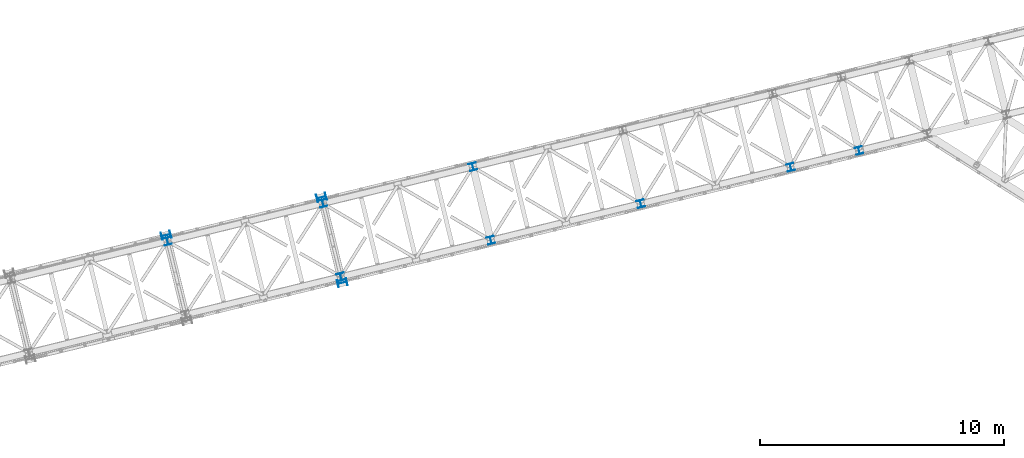
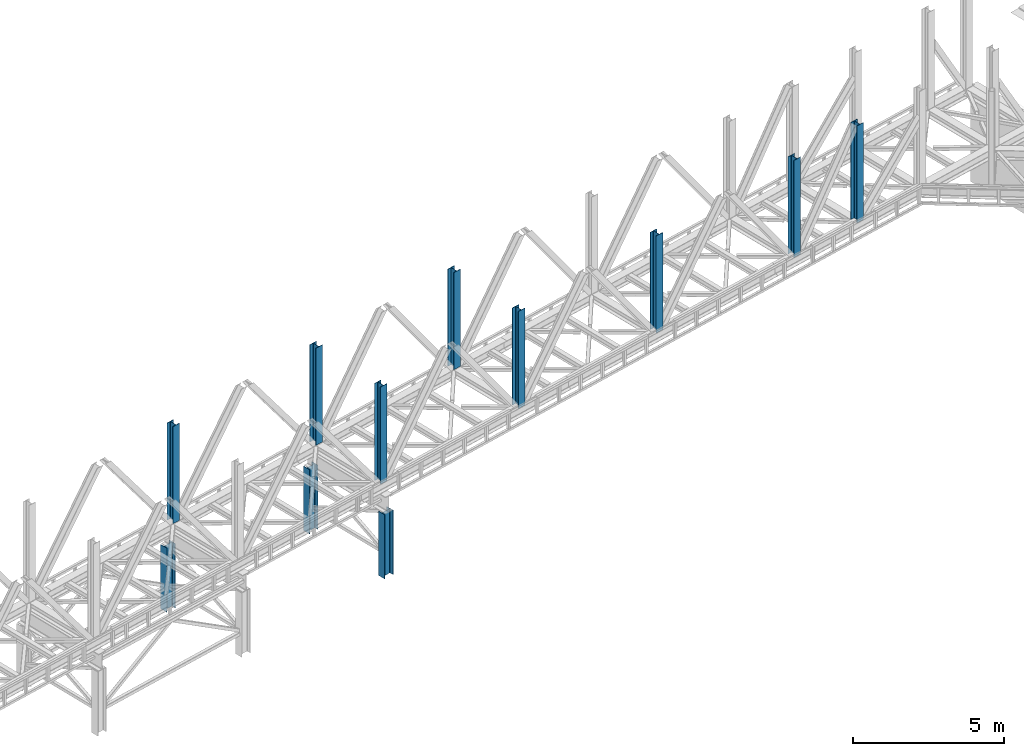
# One storey, part 2 of 92: 11 columns.
"""IFC4 building model written with IfcOpenShell, lengths in millimetres."""

from ifc_helpers import new_model, entity, si_unit, converted_unit, derived_unit, direction, frame, origin, place, context, subcontext, project, spatial, indexed_curve, outline, extrude, type_object, element, save


model = new_model("IFC4")

# Units and contexts
model_context = context("Model", 3, precision=0.01, world=origin(), true_north=direction((6.12303176911189e-17, 1.0)))
plan_context = context("Plan", 3, precision=0.01, world=origin(), true_north=direction((6.12303176911189e-17, 1.0)))
body_context = subcontext(model_context, "Body", "Model", "MODEL_VIEW")
ifc_project = project(units=[si_unit("LENGTHUNIT", "METRE", prefix="MILLI"), si_unit("AREAUNIT", "SQUARE_METRE"), si_unit("VOLUMEUNIT", "CUBIC_METRE"), converted_unit("PLANEANGLEUNIT", "DEGREE", entity("IfcRatioMeasure", 0.0174532925199433), si_unit("PLANEANGLEUNIT", "RADIAN"), dimensions=[0, 0, 0, 0, 0, 0, 0]), si_unit("MASSUNIT", "GRAM", prefix="KILO"), derived_unit("MASSDENSITYUNIT", [(si_unit("MASSUNIT", "GRAM", prefix="KILO"), 1), (si_unit("LENGTHUNIT", "METRE"), -3)]), derived_unit("MOMENTOFINERTIAUNIT", [(si_unit("LENGTHUNIT", "METRE"), 4)]), si_unit("TIMEUNIT", "SECOND"), si_unit("FREQUENCYUNIT", "HERTZ"), si_unit("THERMODYNAMICTEMPERATUREUNIT", "DEGREE_CELSIUS"), derived_unit("THERMALTRANSMITTANCEUNIT", [(si_unit("MASSUNIT", "GRAM", prefix="KILO"), 1), (si_unit("THERMODYNAMICTEMPERATUREUNIT", "KELVIN"), -1), (si_unit("TIMEUNIT", "SECOND"), -3)]), derived_unit("VOLUMETRICFLOWRATEUNIT", [(si_unit("LENGTHUNIT", "METRE"), 3), (si_unit("TIMEUNIT", "SECOND"), -1)]), derived_unit("MASSFLOWRATEUNIT", [(si_unit("MASSUNIT", "GRAM", prefix="KILO"), 1), (si_unit("TIMEUNIT", "SECOND"), -1)]), derived_unit("ROTATIONALFREQUENCYUNIT", [(si_unit("TIMEUNIT", "SECOND"), -1)]), si_unit("ELECTRICCURRENTUNIT", "AMPERE"), si_unit("ELECTRICVOLTAGEUNIT", "VOLT"), si_unit("POWERUNIT", "WATT"), si_unit("FORCEUNIT", "NEWTON", prefix="KILO"), si_unit("ILLUMINANCEUNIT", "LUX"), si_unit("LUMINOUSFLUXUNIT", "LUMEN"), si_unit("LUMINOUSINTENSITYUNIT", "CANDELA"), derived_unit("USERDEFINED", [(si_unit("MASSUNIT", "GRAM", prefix="KILO"), -1), (si_unit("LENGTHUNIT", "METRE"), -2), (si_unit("TIMEUNIT", "SECOND"), 3), (si_unit("LUMINOUSFLUXUNIT", "LUMEN"), 1)]), derived_unit("LINEARVELOCITYUNIT", [(si_unit("LENGTHUNIT", "METRE"), 1), (si_unit("TIMEUNIT", "SECOND"), -1)]), si_unit("PRESSUREUNIT", "PASCAL"), derived_unit("USERDEFINED", [(si_unit("LENGTHUNIT", "METRE"), -2), (si_unit("MASSUNIT", "GRAM", prefix="KILO"), 1), (si_unit("TIMEUNIT", "SECOND"), -2)]), derived_unit("LINEARFORCEUNIT", [(si_unit("MASSUNIT", "GRAM", prefix="KILO"), 1), (si_unit("LENGTHUNIT", "METRE"), 1), (si_unit("TIMEUNIT", "SECOND"), -2), (si_unit("LENGTHUNIT", "METRE"), -1)]), derived_unit("PLANARFORCEUNIT", [(si_unit("MASSUNIT", "GRAM", prefix="KILO"), 1), (si_unit("LENGTHUNIT", "METRE"), 1), (si_unit("TIMEUNIT", "SECOND"), -2), (si_unit("LENGTHUNIT", "METRE"), -2)])], contexts=[model_context, plan_context])

# Site, building, storey
site_placement = place(None, origin())
site = spatial("IfcSite", under=ifc_project, at=site_placement, CompositionType="ELEMENT")
building_placement = place(site_placement, origin())
building = spatial("IfcBuilding", under=site, at=building_placement, CompositionType="ELEMENT")
storey_placement = place(building_placement, frame((0.0, 0.0, 15900.0)))
storey = spatial("IfcBuildingStorey", under=building, at=storey_placement, Name="05", CompositionType="ELEMENT", Elevation=15900.0)

# Columns
column_type_1 = type_object("IfcColumnType", PredefinedType="COLUMN")
placement = place(storey_placement, origin())
element("IfcColumn", 1, at=placement, inside=storey, type_object=column_type_1, ObjectType="Steel Column", PredefinedType="COLUMN", context=body_context, shape_type="SweptSolid", body=[
    extrude(outline(indexed_curve([(-195.999999999997, -150.000000000012), (-179.999999999993, -150.000000000012), (-180.000000000005, -27.7500000000105), (-178.325349715255, -19.3309644879809), (-173.556349186107, -12.1936508139067), (-166.419035512036, -7.42465028476287), (-158.000000000007, -5.75000000001078), (157.999999999993, -5.74999999998623), (166.419035512024, -7.42465028473864), (173.5563491861, -12.19365081388), (178.325349715248, -19.3309644879522), (179.999999999997, -27.7499999999852), (180.000000000005, -149.999999999983), (196.000000000003, -149.999999999984), (195.99999999998, 150.000000000016), (179.999999999985, 150.000000000014), (179.999999999993, 27.7500000000157), (178.325349715242, 19.330964487984), (173.556349186095, 12.1936508139119), (166.419035512023, 7.42465028476595), (157.99999999999, 5.75000000001489), (-158.000000000005, 5.74999999998931), (-166.419035512038, 7.42465028473751), (-173.556349186113, 12.193650813881), (-178.32534971526, 19.3309644879574), (-180.000000000009, 27.7499999999883), (-180.000000000012, 149.999999999987), (-196.000000000016, 149.999999999985), (-195.999999999997, -150.000000000012)], self_intersect=False)), frame((-36585.9, 12131.47, -2.0), z_axis=(0.0, 0.0, 1.0), x_axis=(-0.971552058141491, -0.236826092990264, 0.0)), (0.0, 0.0, 1.0), 2597.00000000003),
])
column_type_2 = type_object("IfcColumnType", PredefinedType="COLUMN")
element("IfcColumn", 2, at=placement, inside=storey, type_object=column_type_2, ObjectType="Steel Column", PredefinedType="COLUMN", context=body_context, shape_type="SweptSolid", body=[
    extrude(outline(indexed_curve([(-195.999999999997, -150.000000000014), (-179.999999999994, -150.000000000014), (-180.000000000001, -27.7500000000136), (-178.325349715246, -19.330964487983), (-173.556349186108, -12.1936508139088), (-166.419035512036, -7.42465028476496), (-158.000000000002, -5.7500000000118), (157.999999999997, -5.74999999998937), (166.419035512032, -7.4246502847407), (173.556349186103, -12.1936508138831), (178.325349715247, -19.3309644879543), (179.999999999996, -27.7499999999873), (180.000000000004, -149.999999999985), (196.000000000012, -149.999999999986), (195.999999999988, 150.000000000014), (179.999999999981, 150.000000000015), (179.999999999992, 27.7500000000136), (178.325349715242, 19.3309644879819), (173.556349186103, 12.1936508139098), (166.419035512032, 7.42465028476389), (157.999999999994, 5.75000000001175), (-158.000000000006, 5.74999999998511), (-166.419035512042, 7.42465028473853), (-173.556349186109, 12.1936508138799), (-178.325349715253, 19.3309644879512), (-180.000000000014, 27.7499999999872), (-180.000000000013, 149.999999999985), (-196.000000000021, 149.999999999986), (-195.999999999997, -150.000000000014)], self_intersect=False)), frame((-29369.65, 10185.09, -1.99), z_axis=(0.0, 0.0, 1.0), x_axis=(-0.971552058141491, -0.236826092990264, 0.0)), (0.0, 0.0, 1.0), 2596.99999999999),
])
column_type_3 = type_object("IfcColumnType", PredefinedType="COLUMN")
element("IfcColumn", 3, at=placement, inside=storey, type_object=column_type_3, ObjectType="Steel Column", PredefinedType="COLUMN", context=body_context, shape_type="SweptSolid", body=[
    extrude(outline(indexed_curve([(-195.99999999998, -150.000000000018), (-179.999999999977, -150.000000000018), (-179.999999999988, -27.7500000000167), (-178.325349715238, -19.330964487985), (-173.556349186095, -12.1936508139119), (-166.419035512024, -7.42465028476805), (-157.999999999986, -5.75000000001591), (158.000000000014, -5.74999999999136), (166.419035512041, -7.42465028474274), (173.556349186116, -12.1936508138862), (178.32534971526, -19.3309644879574), (180.000000000009, -27.7499999999904), (180.000000000017, -149.999999999989), (196.00000000002, -149.999999999989), (195.999999999997, 150.000000000012), (179.999999999997, 150.000000000009), (180.000000000005, 27.7500000000105), (178.325349715254, 19.3309644879788), (173.556349186111, 12.1936508139057), (166.41903551204, 7.42465028476185), (158.00000000001, 5.75000000000765), (-157.99999999998, 5.74999999998316), (-166.41903551202, 7.42465028473551), (-173.556349186095, 12.1936508138811), (-178.325349715243, 19.3309644879533), (-179.999999999988, 27.7499999999831), (-179.999999999997, 149.999999999979), (-196.0, 149.999999999981), (-195.99999999998, -150.000000000018)], self_intersect=False)), frame((-30222.23, 13682.68, -2.0), z_axis=(0.0, 0.0, 1.0), x_axis=(-0.971552058141491, -0.236826092990264, 0.0)), (0.0, 0.0, 1.0), 2597.00000000003),
])
column_type_4 = type_object("IfcColumnType", PredefinedType="COLUMN")
element("IfcColumn", 4, at=placement, inside=storey, type_object=column_type_4, ObjectType="Steel Column", PredefinedType="COLUMN", context=body_context, shape_type="SweptSolid", body=[
    extrude(outline(indexed_curve([(-150.000000000029, -149.999999999968), (-134.500000000028, -149.999999999968), (-134.500000000003, -22.9999999999673), (-133.129831585205, -16.1116982173917), (-129.227922061358, -10.2720779386086), (-123.388301782571, -6.37016841476942), (-116.499999999999, -4.99999999996918), (116.500000000001, -5.00000000001784), (123.388301782572, -6.37016841481622), (129.227922061356, -10.2720779386569), (133.129831585201, -16.1116982174475), (134.499999999996, -23.0000000000225), (134.499999999971, -150.000000000024), (149.999999999971, -150.000000000028), (150.000000000031, 149.999999999977), (134.50000000003, 149.999999999977), (134.500000000006, 22.9999999999799), (133.129831585206, 16.1116982174049), (129.227922061361, 10.2720779386212), (123.388301782575, 6.37016841477732), (116.500000000001, 4.9999999999776), (-116.5, 5.00000000002205), (-123.388301782573, 6.37016841482094), (-129.227922061356, 10.2720779386658), (-133.129831585201, 16.1116982174564), (-134.499999999999, 23.000000000032), (-134.499999999972, 150.000000000028), (-149.999999999969, 150.000000000036), (-150.000000000029, -149.999999999968)], self_intersect=False)), frame((-29428.87, 10427.98, 3685.0), z_axis=(0.0, 0.0, 1.0), x_axis=(-0.236826092990533, 0.971552058141425, 0.0)), (0.0, 0.0, 1.0), 3931.00000000001),
])
column_type_5 = type_object("IfcColumnType", PredefinedType="COLUMN")
element("IfcColumn", 5, at=placement, inside=storey, type_object=column_type_5, ObjectType="Steel Column", PredefinedType="COLUMN", context=body_context, shape_type="SweptSolid", body=[
    extrude(outline(indexed_curve([(-149.999999999989, -150.000000000009), (-134.499999999988, -150.000000000009), (-134.499999999996, -23.0000000000127), (-133.129831585202, -16.111698217441), (-129.227922061358, -10.2720779386521), (-123.388301782571, -6.37016841480712), (-116.499999999999, -5.00000000000502), (116.500000000001, -4.99999999999042), (123.388301782575, -6.37016841478744), (129.227922061359, -10.2720779386307), (133.129831585205, -16.1116982174245), (134.500000000003, -22.9999999999949), (134.500000000013, -149.999999999992), (150.000000000011, -149.999999999991), (149.999999999992, 150.000000000013), (134.499999999991, 150.000000000008), (134.499999999998, 23.0000000000033), (133.129831585202, 16.1116982174321), (129.227922061359, 10.2720779386474), (123.388301782573, 6.37016841480661), (116.500000000002, 5.00000000000871), (-116.499999999999, 4.99999999998991), (-123.388301782572, 6.37016841478693), (-129.227922061357, 10.2720779386302), (-133.129831585205, 16.1116982174156), (-134.500000000002, 22.9999999999902), (-134.50000000001, 149.999999999991), (-150.000000000009, 149.999999999991), (-149.999999999989, -150.000000000009)], self_intersect=False)), frame((-23288.66, 11924.72, 3685.0), z_axis=(0.0, 0.0, 1.0), x_axis=(-0.236826092990269, 0.97155205814149, 0.0)), (0.0, 0.0, 1.0), 3931.00000000001),
])
column_type_6 = type_object("IfcColumnType", PredefinedType="COLUMN")
element("IfcColumn", 6, at=placement, inside=storey, type_object=column_type_6, ObjectType="Steel Column", PredefinedType="COLUMN", context=body_context, shape_type="SweptSolid", body=[
    extrude(outline(indexed_curve([(-149.99999999999, -150.000000000013), (-134.499999999989, -150.000000000013), (-134.499999999999, -23.0000000000143), (-133.129831585202, -16.1116982174342), (-129.227922061359, -10.2720779386563), (-123.388301782571, -6.3701684147982), (-116.5, -5.0000000000003), (116.500000000001, -4.9999999999836), (123.388301782571, -6.3701684147822), (129.227922061357, -10.2720779386391), (133.129831585205, -16.1116982174156), (134.5, -22.9999999999965), (134.50000000001, -149.999999999993), (150.000000000011, -149.999999999991), (149.999999999989, 150.000000000009), (134.499999999988, 150.000000000009), (134.499999999998, 23.0000000000101), (133.129831585201, 16.11169821743), (129.227922061358, 10.2720779386432), (123.388301782572, 6.37016841481134), (116.499999999999, 5.00000000001395), (-116.500000000005, 4.99999999999355), (-123.388301782578, 6.37016841479056), (-129.22792206136, 10.2720779386286), (-133.129831585208, 16.1116982174119), (-134.500000000004, 22.9999999999997), (-134.500000000012, 149.999999999994), (-150.000000000012, 149.999999999987), (-149.99999999999, -150.000000000013)], self_intersect=False)), frame((-17148.45, 13421.46, 3685.0), z_axis=(0.0, 0.0, 1.0), x_axis=(-0.236826092990269, 0.97155205814149, 0.0)), (0.0, 0.0, 1.0), 3931.00000000001),
])
column_type_7 = type_object("IfcColumnType", PredefinedType="COLUMN")
element("IfcColumn", 7, at=placement, inside=storey, type_object=column_type_7, ObjectType="Steel Column", PredefinedType="COLUMN", context=body_context, shape_type="SweptSolid", body=[
    extrude(outline(indexed_curve([(-149.999999999989, -150.000000000011), (-134.499999999989, -150.000000000011), (-134.499999999998, -23.0000000000033), (-133.129831585202, -16.111698217441), (-129.227922061358, -10.2720779386542), (-123.388301782572, -6.37016841480451), (-116.5, -5.00000000000713), (116.500000000001, -4.99999999999042), (123.388301782572, -6.37016841478903), (129.227922061358, -10.272077938637), (133.129831585205, -16.1116982174224), (134.500000000003, -22.999999999986), (134.50000000001, -149.999999999991), (150.000000000011, -149.999999999989), (149.999999999989, 150.000000000011), (134.499999999989, 150.000000000011), (134.499999999998, 23.0000000000122), (133.129831585202, 16.111698217441), (129.227922061356, 10.2720779386547), (123.38830178257, 6.37016841480503), (116.5, 5.00000000000713), (-116.500000000003, 4.99999999998411), (-123.388301782573, 6.37016841478482), (-129.227922061361, 10.2720779386312), (-133.129831585207, 16.1116982174229), (-134.500000000004, 22.9999999999907), (-134.500000000014, 149.999999999988), (-150.000000000011, 149.999999999989), (-149.999999999989, -150.000000000011)], self_intersect=False)), frame((-11008.24, 14918.2, 3685.0), z_axis=(0.0, 0.0, 1.0), x_axis=(-0.236826092990269, 0.97155205814149, 0.0)), (0.0, 0.0, 1.0), 3931.00000000001),
])
column_type_8 = type_object("IfcColumnType", PredefinedType="COLUMN")
element("IfcColumn", 8, at=placement, inside=storey, type_object=column_type_8, ObjectType="Steel Column", PredefinedType="COLUMN", context=body_context, shape_type="SweptSolid", body=[
    extrude(outline(indexed_curve([(-150.000000000006, -149.999999999994), (-134.500000000008, -149.999999999994), (-134.500000000003, -22.9999999999892), (-133.129831585205, -16.111698217426), (-129.227922061361, -10.2720779386396), (-123.388301782575, -6.37016841479049), (-116.500000000002, -4.9999999999938), (116.499999999999, -5.00000000000062), (123.38830178257, -6.37016841479887), (129.227922061355, -10.2720779386485), (133.129831585202, -16.1116982174343), (134.499999999999, -22.999999999997), (134.499999999993, -150.000000000003), (149.999999999994, -150.000000000004), (150.000000000002, 149.999999999998), (134.500000000002, 149.999999999998), (134.499999999999, 22.9999999999923), (133.129831585202, 16.1116982174291), (129.227922061355, 10.2720779386353), (123.388301782569, 6.37016841480306), (116.499999999998, 5.00000000000586), (-116.500000000006, 4.99999999999901), (-123.388301782581, 6.37016841479828), (-129.227922061362, 10.2720779386369), (-133.12983158521, 16.1116982174374), (-134.500000000003, 22.999999999998), (-134.5, 150.000000000003), (-149.999999999998, 150.000000000007), (-150.000000000006, -149.999999999994)], self_intersect=False)), frame((-8210.17, 15600.26, 3685.0), z_axis=(0.0, 0.0, 1.0), x_axis=(-0.236826092990367, 0.971552058141466, 0.0)), (0.0, 0.0, 1.0), 3931.00000000001),
])
column_type_9 = type_object("IfcColumnType", PredefinedType="COLUMN")
element("IfcColumn", 9, at=placement, inside=storey, type_object=column_type_9, ObjectType="Steel Column", PredefinedType="COLUMN", context=body_context, shape_type="SweptSolid", body=[
    extrude(outline(indexed_curve([(-149.999999999993, -149.999999999999), (-134.499999999993, -149.999999999999), (-134.500000000002, -22.999999999998), (-133.129831585206, -16.1116982174221), (-129.227922061361, -10.2720779386379), (-123.388301782575, -6.37016841479717), (-116.500000000001, -4.99999999999558), (116.499999999997, -4.99999999998047), (123.388301782568, -6.37016841477697), (129.227922061356, -10.2720779386165), (133.1298315852, -16.1116982174056), (134.499999999999, -22.9999999999808), (134.500000000008, -149.999999999982), (150.000000000008, -149.999999999982), (149.999999999987, 150.000000000023), (134.499999999986, 150.000000000018), (134.499999999996, 23.0000000000216), (133.129831585199, 16.1116982174462), (129.227922061353, 10.272077938662), (123.388301782568, 6.37016841481657), (116.499999999998, 5.00000000001867), (-116.500000000001, 4.99999999999935), (-123.388301782572, 6.37016841479585), (-129.227922061361, 10.2720779386401), (-133.129831585206, 16.1116982174292), (-134.500000000005, 23.0000000000044), (-134.500000000013, 150.000000000001), (-150.000000000013, 150.000000000001), (-149.999999999993, -149.999999999999)], self_intersect=False)), frame((-30163.03, 13439.79, 3685.0), z_axis=(0.0, 0.0, 1.0), x_axis=(-0.236826092990269, 0.97155205814149, 0.0)), (0.0, 0.0, 1.0), 3931.00000000001),
])
column_type_10 = type_object("IfcColumnType", PredefinedType="COLUMN")
element("IfcColumn", 10, at=placement, inside=storey, type_object=column_type_10, ObjectType="Steel Column", PredefinedType="COLUMN", context=body_context, shape_type="SweptSolid", body=[
    extrude(outline(indexed_curve([(-149.999999999984, -150.000000000001), (-134.499999999984, -150.000000000001), (-134.499999999993, -23.0000000000001), (-133.129831585198, -16.1116982174331), (-129.227922061352, -10.2720779386489), (-123.388301782564, -6.37016841479973), (-116.499999999994, -5.00000000000184), (116.500000000006, -4.99999999998724), (123.388301782578, -6.37016841478374), (129.227922061365, -10.2720779386275), (133.12983158521, -16.1116982174124), (134.500000000008, -22.9999999999828), (134.500000000017, -149.999999999984), (150.000000000017, -149.999999999984), (149.999999999996, 150.000000000021), (134.499999999995, 150.000000000016), (134.500000000004, 23.0000000000154), (133.129831585207, 16.1116982174442), (129.227922061363, 10.2720779386642), (123.388301782577, 6.37016841481452), (116.500000000006, 5.00000000001662), (-116.499999999996, 5.00000000000253), (-123.388301782565, 6.37016841479852), (-129.227922061355, 10.2720779386475), (-133.129831585197, 16.1116982174272), (-134.499999999996, 23.0000000000023), (-134.500000000004, 149.999999999999), (-150.000000000004, 149.999999999999), (-149.999999999984, -150.000000000001)], self_intersect=False)), frame((-24022.82, 14936.53, 3685.0), z_axis=(0.0, 0.0, 1.0), x_axis=(-0.236826092990269, 0.97155205814149, 0.0)), (0.0, 0.0, 1.0), 3931.00000000001),
])
column_type_11 = type_object("IfcColumnType", PredefinedType="COLUMN")
element("IfcColumn", 11, at=placement, inside=storey, type_object=column_type_11, ObjectType="Steel Column", PredefinedType="COLUMN", context=body_context, shape_type="SweptSolid", body=[
    extrude(outline(indexed_curve([(-149.999999999989, -150.000000000009), (-134.499999999988, -150.000000000009), (-134.499999999997, -23.000000000008), (-133.129831585201, -16.1116982174368), (-129.227922061355, -10.2720779386526), (-123.388301782571, -6.37016841480713), (-116.499999999997, -5.00000000000553), (116.500000000001, -4.99999999999042), (123.388301782572, -6.37016841478692), (129.227922061361, -10.2720779386312), (133.129831585206, -16.1116982174203), (134.500000000004, -22.9999999999907), (134.500000000013, -149.999999999992), (150.000000000013, -149.999999999992), (149.999999999992, 150.000000000013), (134.499999999991, 150.000000000008), (134.499999999999, 23.0000000000075), (133.129831585203, 16.1116982174363), (129.22792206136, 10.2720779386516), (123.388301782573, 6.37016841480661), (116.500000000002, 5.00000000000872), (-116.499999999998, 4.99999999999412), (-123.388301782569, 6.37016841479062), (-129.227922061358, 10.2720779386349), (-133.129831585203, 16.1116982174151), (-134.500000000001, 22.9999999999944), (-134.500000000007, 149.999999999995), (-150.000000000009, 149.999999999991), (-149.999999999989, -150.000000000009)], self_intersect=False)), frame((-36526.69, 11888.58, 3685.0), z_axis=(0.0, 0.0, 1.0), x_axis=(-0.236826092990269, 0.97155205814149, 0.0)), (0.0, 0.0, 1.0), 3931.00000000001),
])

save(model, "model.ifc")
